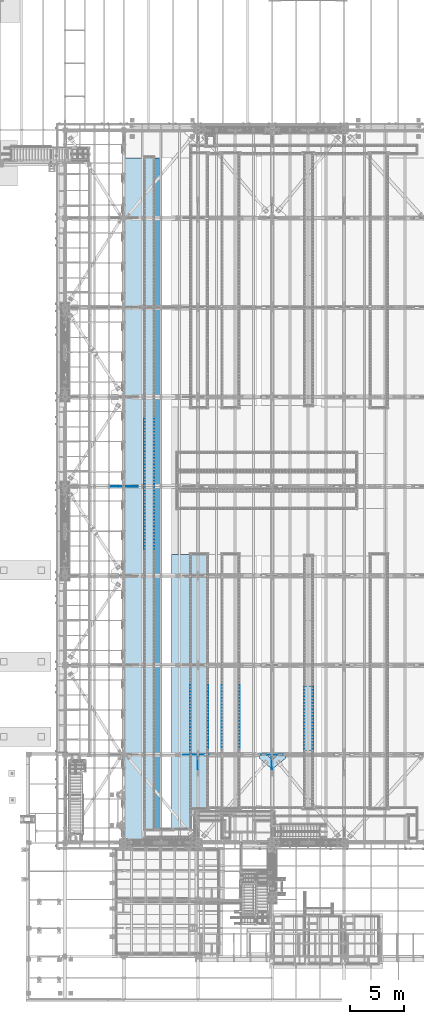
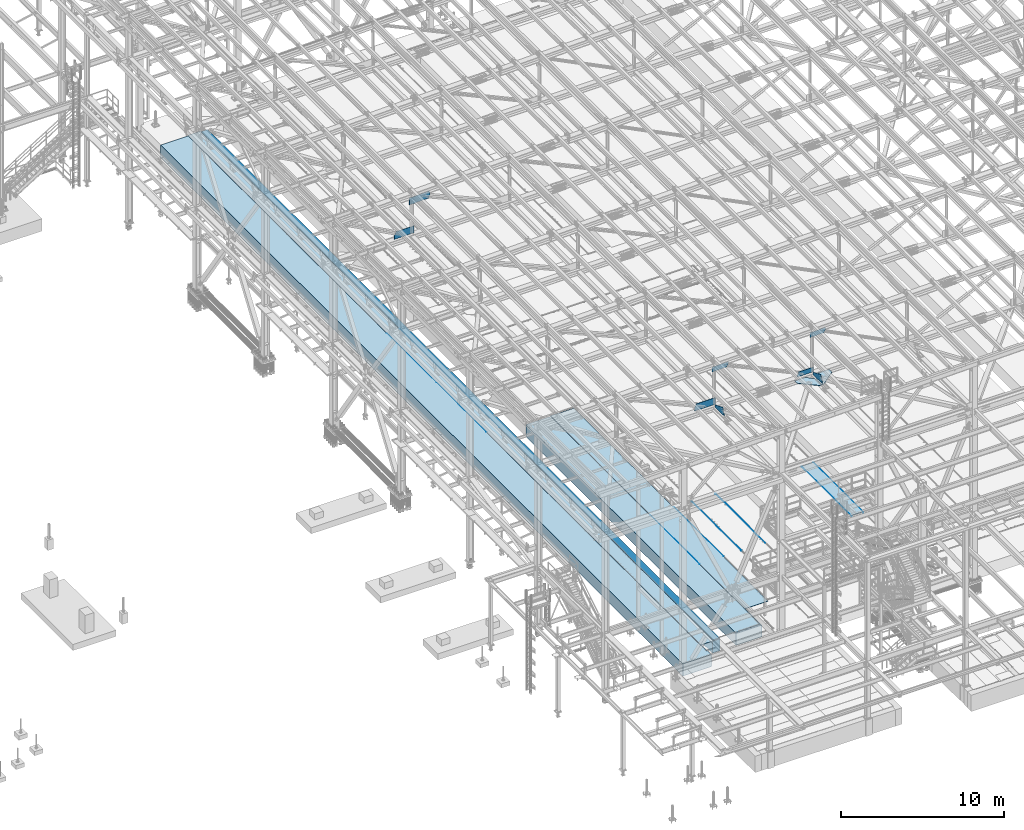
# One storey, part 2979 of 3843: 23 plates, 3 slabs, 24 elements without a shape of their own.
"""IFC2X3 building model written with IfcOpenShell, lengths in millimetres."""

from ifc_helpers import new_model, si_unit, frame, origin_with_axes, place, context, subcontext, project, spatial, faceted_brep, material, type_object, element, aggregate, save


model = new_model("IFC2X3")

# Units and contexts
model_context = context("Model", 3, precision=1e-05, world=origin_with_axes())
body_context = subcontext(model_context, "Body", "Model", "MODEL_VIEW")
ifc_project = project(units=[si_unit("LENGTHUNIT", "METRE", prefix="MILLI"), si_unit("AREAUNIT", "SQUARE_METRE"), si_unit("VOLUMEUNIT", "CUBIC_METRE"), si_unit("MASSUNIT", "GRAM", prefix="KILO"), si_unit("TIMEUNIT", "SECOND"), si_unit("PLANEANGLEUNIT", "RADIAN"), si_unit("SOLIDANGLEUNIT", "STERADIAN"), si_unit("THERMODYNAMICTEMPERATUREUNIT", "DEGREE_CELSIUS"), si_unit("LUMINOUSINTENSITYUNIT", "LUMEN")], contexts=[model_context])

# Site, building, storey
site_placement = place(None, origin_with_axes())
site = spatial("IfcSite", under=ifc_project, at=site_placement, CompositionType="ELEMENT")
building_placement = place(site_placement, origin_with_axes())
building = spatial("IfcBuilding", under=site, at=building_placement, Name="Undefined", CompositionType="ELEMENT")
storey_placement = place(building_placement, origin_with_axes())
storey = spatial("IfcBuildingStorey", under=building, at=storey_placement, Name="Undefined", CompositionType="ELEMENT", Elevation=0.0)

# Assembly, plate
assembly_1_placement = place(storey_placement, origin_with_axes())
assembly_1 = element("IfcElementAssembly", 1, at=assembly_1_placement, inside=storey, Name="EMBED_ANGLE", AssemblyPlace="NOTDEFINED", PredefinedType="RIGID_FRAME")
ifc_material_1 = material(Name="STEEL/A36")
plate_type_1 = type_object("IfcPlateType", PredefinedType="NOTDEFINED")
plate_1_placement = place(assembly_1_placement, frame((59735.2121396484, 40208.072265625, 30479.9999996185), z_axis=(0.0, -1.0, 0.0), x_axis=(0.0, 0.0, -1.0)))
plate_1 = element("IfcPlate", 2, at=plate_1_placement, type_object=plate_type_1, material=ifc_material_1, Name="PLATE", context=body_context, shape_type="Brep", body=[
    faceted_brep([(25.4000008230432, 1.58705903157534, 6096.0), (25.3999996185303, 1.58706242449261, 0.0), (20.6374996185295, 6.35000000000218, -7.27595761418343e-12), (20.6374984696922, 6.35000000000582, 6096.0), (0.0, -6.3499999046162, 0.0), (3.81471181754023e-07, -6.34999999999854, 6096.0), (3.81471181754023e-07, 6.34999999999854, 6096.0), (7.27595761418343e-12, 6.3499999046162, 0.0), (25.3999996185303, -6.34999999999491, 2.91038304567337e-11), (25.3999996185303, -6.35000000000582, 6096.0)], [[[0, 1, 2, 3]], [[4, 5, 6, 7]], [[8, 9, 5, 4]], [[6, 5, 9, 0, 3]], [[7, 6, 3, 2]], [[8, 4, 7, 2, 1]], [[9, 8, 1, 0]]]),
])
aggregate(assembly_1, [plate_1])

assembly_2_placement = place(storey_placement, origin_with_axes())
assembly_2 = element("IfcElementAssembly", 3, at=assembly_2_placement, inside=storey, Name="EMBED_ANGLE", AssemblyPlace="NOTDEFINED", PredefinedType="RIGID_FRAME")
plate_2_placement = place(assembly_2_placement, frame((58909.7753603516, 40208.072265625, 30479.9999996185), z_axis=(0.0, -1.0, 0.0), x_axis=(0.0, 0.0, -1.0)))
plate_2 = element("IfcPlate", 4, at=plate_2_placement, type_object=plate_type_1, material=ifc_material_1, Name="PLATE", context=body_context, shape_type="Brep", body=[
    faceted_brep([(25.3999996185521, -1.58750000003783, 6096.0), (20.6375003814719, -6.34999999999854, 6096.00000000139), (20.6375000381231, -6.35000000004948, 2.5465851649642e-11), (25.3999996185921, -1.5874999999869, 7.27595761418343e-11), (0.0, -6.3499999046162, 0.0), (3.81471181754023e-07, -6.34999999999854, 6096.0), (3.81471181754023e-07, 6.34999999999854, 6096.0), (7.27595761418343e-12, 6.3499999046162, 0.0), (25.3999996185303, 6.34999999999854, 6096.00000000171), (25.3999999999942, 6.34999999994034, 2.91038304567337e-11)], [[[0, 1, 2, 3]], [[4, 5, 6, 7]], [[8, 9, 7, 6]], [[9, 8, 0, 3]], [[4, 7, 9, 3, 2]], [[5, 4, 2, 1]], [[8, 6, 5, 1, 0]]]),
])
aggregate(assembly_2, [plate_2])

assembly_3_placement = place(storey_placement, origin_with_axes())
assembly_3 = element("IfcElementAssembly", 5, at=assembly_3_placement, inside=storey, Name="EMBED_ANGLE", AssemblyPlace="NOTDEFINED", PredefinedType="RIGID_FRAME")
plate_3_placement = place(assembly_3_placement, frame((52889.8485419922, 40360.599609375, 30479.9999996185), z_axis=(0.0, -1.0, 0.0), x_axis=(0.0, 0.0, -1.0)))
plate_3 = element("IfcPlate", 6, at=plate_3_placement, type_object=plate_type_1, material=ifc_material_1, Name="PLATE", context=body_context, shape_type="Brep", body=[
    faceted_brep([(25.4000008230432, 1.58705903157534, 6096.0), (25.3999996185303, 1.58706242449261, 0.0), (20.6374996185295, 6.35000000000218, -7.27595761418343e-12), (20.6374984696922, 6.35000000000582, 6096.0), (0.0, -6.3499999046162, 0.0), (3.81471181754023e-07, -6.34999999999854, 6096.0), (3.81471181754023e-07, 6.34999999999854, 6096.0), (7.27595761418343e-12, 6.3499999046162, 0.0), (25.3999996185303, -6.34999999999491, 2.91038304567337e-11), (25.3999996185303, -6.35000000000582, 6096.0)], [[[0, 1, 2, 3]], [[4, 5, 6, 7]], [[8, 9, 5, 4]], [[6, 5, 9, 0, 3]], [[7, 6, 3, 2]], [[8, 4, 7, 2, 1]], [[9, 8, 1, 0]]]),
])
aggregate(assembly_3, [plate_3])

assembly_4_placement = place(storey_placement, origin_with_axes())
assembly_4 = element("IfcElementAssembly", 7, at=assembly_4_placement, inside=storey, Name="EMBED_ANGLE", AssemblyPlace="NOTDEFINED", PredefinedType="RIGID_FRAME")
plate_4_placement = place(assembly_4_placement, frame((51200.811984375, 40360.599609375, 30479.9999996185), z_axis=(0.0, -1.0, 0.0), x_axis=(0.0, 0.0, -1.0)))
plate_4 = element("IfcPlate", 8, at=plate_4_placement, type_object=plate_type_1, material=ifc_material_1, Name="PLATE", context=body_context, shape_type="Brep", body=[
    faceted_brep([(25.3999996185521, -1.58750000003783, 6096.0), (20.6375003814719, -6.34999999999854, 6096.00000000139), (20.6375000381231, -6.35000000004948, 2.5465851649642e-11), (25.3999996185921, -1.5874999999869, 7.27595761418343e-11), (0.0, -6.3499999046162, 0.0), (3.81471181754023e-07, -6.34999999999854, 6096.0), (3.81471181754023e-07, 6.34999999999854, 6096.0), (7.27595761418343e-12, 6.3499999046162, 0.0), (25.3999996185303, 6.34999999999854, 6096.00000000171), (25.3999999999942, 6.34999999994034, 2.91038304567337e-11)], [[[0, 1, 2, 3]], [[4, 5, 6, 7]], [[8, 9, 7, 6]], [[9, 8, 0, 3]], [[4, 7, 9, 3, 2]], [[5, 4, 2, 1]], [[8, 6, 5, 1, 0]]]),
])
aggregate(assembly_4, [plate_4])

assembly_5_placement = place(storey_placement, origin_with_axes())
assembly_5 = element("IfcElementAssembly", 9, at=assembly_5_placement, inside=storey, Name="EMBED_ANGLE", AssemblyPlace="NOTDEFINED", PredefinedType="RIGID_FRAME")
plate_5_placement = place(assembly_5_placement, frame((49949.8620576172, 40360.599609375, 30479.9999996185), z_axis=(0.0, -1.0, 0.0), x_axis=(0.0, 0.0, -1.0)))
plate_5 = element("IfcPlate", 10, at=plate_5_placement, type_object=plate_type_1, material=ifc_material_1, Name="PLATE", context=body_context, shape_type="Brep", body=[
    faceted_brep([(25.4000008230432, 1.58705903157534, 6096.0), (25.3999996185303, 1.58706242449261, 0.0), (20.6374996185295, 6.35000000000218, -7.27595761418343e-12), (20.6374984696922, 6.35000000000582, 6096.0), (0.0, -6.3499999046162, 0.0), (3.81471181754023e-07, -6.34999999999854, 6096.0), (3.81471181754023e-07, 6.34999999999854, 6096.0), (7.27595761418343e-12, 6.3499999046162, 0.0), (25.3999996185303, -6.34999999999491, 2.91038304567337e-11), (25.3999996185303, -6.35000000000582, 6096.0)], [[[0, 1, 2, 3]], [[4, 5, 6, 7]], [[8, 9, 5, 4]], [[6, 5, 9, 0, 3]], [[7, 6, 3, 2]], [[8, 4, 7, 2, 1]], [[9, 8, 1, 0]]]),
])
aggregate(assembly_5, [plate_5])

assembly_6_placement = place(storey_placement, origin_with_axes())
assembly_6 = element("IfcElementAssembly", 11, at=assembly_6_placement, inside=storey, Name="EMBED_ANGLE", AssemblyPlace="NOTDEFINED", PredefinedType="RIGID_FRAME")
plate_6_placement = place(assembly_6_placement, frame((48260.7616210937, 40360.6001953125, 30479.9999996185), z_axis=(0.0, -1.0, 0.0), x_axis=(0.0, 0.0, -1.0)))
plate_6 = element("IfcPlate", 12, at=plate_6_placement, type_object=plate_type_1, material=ifc_material_1, Name="PLATE", context=body_context, shape_type="Brep", body=[
    faceted_brep([(25.3999996185521, -1.58750000003783, 6096.0), (20.6375003814719, -6.34999999999854, 6096.00000000139), (20.6375000381231, -6.35000000004948, 2.5465851649642e-11), (25.3999996185921, -1.5874999999869, 7.27595761418343e-11), (0.0, -6.3499999046162, 0.0), (3.81471181754023e-07, -6.34999999999854, 6096.0), (3.81471181754023e-07, 6.34999999999854, 6096.0), (7.27595761418343e-12, 6.3499999046162, 0.0), (25.3999996185303, 6.34999999999854, 6096.00000000171), (25.3999999999942, 6.34999999994034, 2.91038304567337e-11)], [[[0, 1, 2, 3]], [[4, 5, 6, 7]], [[8, 9, 7, 6]], [[9, 8, 0, 3]], [[4, 7, 9, 3, 2]], [[5, 4, 2, 1]], [[8, 6, 5, 1, 0]]]),
])
aggregate(assembly_6, [plate_6])

assembly_7_placement = place(storey_placement, origin_with_axes())
assembly_7 = element("IfcElementAssembly", 13, at=assembly_7_placement, inside=storey, Name="PLATE", AssemblyPlace="NOTDEFINED", PredefinedType="RIGID_FRAME")
ifc_material_2 = material(Name="STEEL/A572-50")
plate_type_2 = type_object("IfcPlateType", PredefinedType="NOTDEFINED")
plate_7_placement = place(assembly_7_placement, frame((58922.4753962742, 34175.5721406259, 30467.3), z_axis=(0.0, 1.0, 0.0), x_axis=(1.0, 0.0, 0.0)))
plate_7 = element("IfcPlate", 14, at=plate_7_placement, type_object=plate_type_2, material=ifc_material_2, Name="PLATE", context=body_context, shape_type="Brep", body=[
    faceted_brep([(0.0, -12.6999999999971, 0.0), (-0.00374851834203582, -12.7000000000007, 6095.99999999916), (-0.00374851834203582, 12.7000000000007, 6095.99999999916), (0.0, 12.6999999999971, 0.0), (800.03667504531, -12.7000000000007, 6096.00000000056), (800.03667504531, 12.7000000000007, 6096.00000000056), (800.036639650629, -12.7000000000007, 5.49334799870849e-10), (800.036639650629, 12.7000000000007, 5.49334799870849e-10)], [[[0, 1, 2, 3]], [[1, 4, 5, 2]], [[4, 6, 7, 5]], [[6, 0, 3, 7]], [[5, 7, 3, 2]], [[6, 4, 1, 0]]]),
])
aggregate(assembly_7, [plate_7])

assembly_8_placement = place(storey_placement, origin_with_axes())
assembly_8 = element("IfcElementAssembly", 15, at=assembly_8_placement, inside=storey, Name="BEAM", AssemblyPlace="NOTDEFINED", PredefinedType="RIGID_FRAME")
plate_type_3 = type_object("IfcPlateType", PredefinedType="NOTDEFINED")
plate_8_placement = place(assembly_8_placement, frame((42268.3401981071, 58915.2999999999, 42463.0727281937), z_axis=(-0.00524699200232136, 0.0, 0.999986234442719), x_axis=(-0.999986234442719, 0.0, -0.00524699200232052)))
plate_8 = element("IfcPlate", 16, at=plate_8_placement, type_object=plate_type_3, material=ifc_material_2, Name="PLATE", context=body_context, shape_type="Brep", body=[
    faceted_brep([(0.0, -9.52500000000146, 0.0), (1.229636836797e-09, -9.52500000000146, 522.241740626429), (1.229636836797e-09, 9.52500000000146, 522.241740626429), (0.0, 9.52500000000146, 0.0), (1253.2324914307, -9.52500000000146, 528.817531697183), (1253.2324914307, 9.52500000000146, 528.817531697183), (1398.7446886287, -9.52500000000146, 260.994378102703), (1398.7446886287, 9.52500000000146, 260.994378102703), (1398.74468862808, -9.52500000000146, -3.32511262968183e-09), (1398.74468862808, 9.52500000000146, -3.32511262968183e-09)], [[[0, 1, 2, 3]], [[1, 4, 5, 2]], [[4, 6, 7, 5]], [[6, 8, 9, 7]], [[8, 0, 3, 9]], [[5, 7, 9, 3, 2]], [[8, 6, 4, 1, 0]]]),
])
aggregate(assembly_8, [plate_8])

assembly_9_placement = place(storey_placement, origin_with_axes())
assembly_9 = element("IfcElementAssembly", 17, at=assembly_9_placement, inside=storey, Name="TRENCH COVER", AssemblyPlace="NOTDEFINED", PredefinedType="RIGID_FRAME")
ifc_material_3 = material(Name="STEEL/Steel_Undefined")
plate_type_4 = type_object("IfcPlateType", PredefinedType="NOTDEFINED")
plate_9_placement = place(assembly_9_placement, frame((48279.8099164624, 28809.9499739415, 30467.3), z_axis=(0.0, 1.0, 0.0), x_axis=(1.0, 0.0, 0.0)))
plate_9 = element("IfcPlate", 18, at=plate_9_placement, type_object=plate_type_4, material=ifc_material_3, Name="TRENCH COVER", context=body_context, shape_type="Brep", body=[
    faceted_brep([(0.0, -12.6999999999971, 0.0), (0.00638351428642636, -12.7000000000007, 23806.1500596228), (0.00638351428642636, 12.7000000000007, 23806.1500596228), (0.0, 12.6999999999971, 0.0), (1651.00000084208, -12.7000000000007, 23806.1500595694), (1651.00000084208, 12.7000000000007, 23806.1500595694), (1651.0, -12.7000000000007, 0.0), (1651.0, 12.7000000000007, 0.0)], [[[0, 1, 2, 3]], [[1, 4, 5, 2]], [[4, 6, 7, 5]], [[6, 0, 3, 7]], [[5, 7, 3, 2]], [[6, 4, 1, 0]]]),
])
aggregate(assembly_9, [plate_9])

assembly_10_placement = place(storey_placement, origin_with_axes())
assembly_10 = element("IfcElementAssembly", 19, at=assembly_10_placement, inside=storey, Name="TRENCH COVER", AssemblyPlace="NOTDEFINED", PredefinedType="RIGID_FRAME")
plate_type_5 = type_object("IfcPlateType", PredefinedType="NOTDEFINED")
plate_10_placement = place(assembly_10_placement, frame((44017.9460147894, 26806.5255152289, 30472.0625), z_axis=(0.0, 1.0, 0.0), x_axis=(1.0, 0.0, 0.0)))
plate_10 = element("IfcPlate", 20, at=plate_10_placement, type_object=plate_type_5, material=ifc_material_3, Name="TRENCH COVER", context=body_context, shape_type="Brep", body=[
    faceted_brep([(0.0, -7.9375, 0.0), (0.000500683752761688, -7.9375, 62871.3494847712), (0.000500683752761688, 7.9375, 62871.3494847712), (0.0, 7.9375, 0.0), (889.000485894358, -7.9375, 62871.3494776559), (889.000485894358, 7.9375, 62871.3494776559), (888.99997705764, -7.9375, 4.51109372079372e-10), (888.99997705764, 7.9375, 4.51109372079372e-10)], [[[0, 1, 2, 3]], [[1, 4, 5, 2]], [[4, 6, 7, 5]], [[6, 0, 3, 7]], [[5, 7, 3, 2]], [[6, 4, 1, 0]]]),
])
aggregate(assembly_10, [plate_10])

assembly_11_placement = place(storey_placement, origin_with_axes())
assembly_11 = element("IfcElementAssembly", 21, at=assembly_11_placement, inside=storey, Name="EMBED_ANGLE", AssemblyPlace="NOTDEFINED", PredefinedType="RIGID_FRAME")
plate_type_6 = type_object("IfcPlateType", PredefinedType="NOTDEFINED")
plate_11_placement = place(assembly_11_placement, frame((44925.9959999999, 59134.3749999999, 30479.9999984742), z_axis=(0.0, -1.0, 0.0), x_axis=(0.0, 0.0, -1.0)))
plate_11 = element("IfcPlate", 22, at=plate_11_placement, type_object=plate_type_6, material=ifc_material_1, Name="PLATE", context=body_context, shape_type="Brep", body=[
    faceted_brep([(15.875, 1.58750000000146, 6096.0), (15.875, 1.58749999204883, -3.63797880709171e-12), (11.1125018504281, 6.35000000000582, -7.27595761418343e-12), (11.1124996186481, 6.34999999999854, 6096.0), (0.0, -6.3499999046162, 0.0), (3.81471181754023e-07, -6.34999999999854, 6096.0), (3.81471181754023e-07, 6.34999999999854, 6096.0), (7.27595761418343e-12, 6.3499999046162, 0.0), (15.875, -6.35000000000582, 3.63797880709171e-12), (15.875, -6.34999999999854, 6096.0)], [[[0, 1, 2, 3]], [[4, 5, 6, 7]], [[8, 9, 5, 4]], [[6, 5, 9, 0, 3]], [[7, 6, 3, 2]], [[8, 4, 7, 2, 1]], [[9, 8, 1, 0]]]),
])
aggregate(assembly_11, [plate_11])

assembly_12_placement = place(storey_placement, origin_with_axes())
assembly_12 = element("IfcElementAssembly", 23, at=assembly_12_placement, inside=storey, Name="EMBED_ANGLE", AssemblyPlace="NOTDEFINED", PredefinedType="RIGID_FRAME")
plate_12_placement = place(assembly_12_placement, frame((44925.996, 65230.375, 30479.9999988556), z_axis=(0.0, -1.0, 0.0), x_axis=(0.0, 0.0, -1.0)))
plate_12 = element("IfcPlate", 24, at=plate_12_placement, type_object=plate_type_6, material=ifc_material_1, Name="PLATE", context=body_context, shape_type="Brep", body=[
    faceted_brep([(15.875, 1.58750000000146, 6096.0), (15.875, 1.58749999204883, -3.63797880709171e-12), (11.1125018504281, 6.35000000000582, -7.27595761418343e-12), (11.1124996186481, 6.34999999999854, 6096.0), (0.0, -6.3499999046162, 0.0), (3.81471181754023e-07, -6.34999999999854, 6096.0), (3.81471181754023e-07, 6.34999999999854, 6096.0), (7.27595761418343e-12, 6.3499999046162, 0.0), (15.875, -6.35000000000582, 3.63797880709171e-12), (15.875, -6.34999999999854, 6096.0)], [[[0, 1, 2, 3]], [[4, 5, 6, 7]], [[8, 9, 5, 4]], [[6, 5, 9, 0, 3]], [[7, 6, 3, 2]], [[8, 4, 7, 2, 1]], [[9, 8, 1, 0]]]),
])
aggregate(assembly_12, [plate_12])

assembly_13_placement = place(storey_placement, origin_with_axes())
assembly_13 = element("IfcElementAssembly", 25, at=assembly_13_placement, inside=storey, Name="EMBED_ANGLE", AssemblyPlace="NOTDEFINED", PredefinedType="RIGID_FRAME")
plate_13_placement = place(assembly_13_placement, frame((43998.896, 59134.375, 30479.9999988556), z_axis=(0.0, -1.0, 0.0), x_axis=(0.0, 0.0, -1.0)))
plate_13 = element("IfcPlate", 26, at=plate_13_placement, type_object=plate_type_6, material=ifc_material_1, Name="PLATE", context=body_context, shape_type="Brep", body=[
    faceted_brep([(15.8749946755343, -1.58750000000146, 6096.0), (11.1124999999702, -6.34999999999854, 6096.0), (11.1125001907349, -6.35000000006371, 0.0), (15.875, -1.58750000024156, -3.63797880709171e-12), (0.0, -6.3499999046162, 0.0), (3.81471181754023e-07, -6.34999999999854, 6096.0), (3.81471181754023e-07, 6.34999999999854, 6096.0), (7.27595761418343e-12, 6.3499999046162, 0.0), (15.875, 6.34999999999854, 6096.0), (15.875, 6.34999999999854, -3.63797880709171e-12)], [[[0, 1, 2, 3]], [[4, 5, 6, 7]], [[8, 9, 7, 6]], [[9, 8, 0, 3]], [[4, 7, 9, 3, 2]], [[5, 4, 2, 1]], [[8, 6, 5, 1, 0]]]),
])
aggregate(assembly_13, [plate_13])

assembly_14_placement = place(storey_placement, origin_with_axes())
assembly_14 = element("IfcElementAssembly", 27, at=assembly_14_placement, inside=storey, Name="EMBED_ANGLE", AssemblyPlace="NOTDEFINED", PredefinedType="RIGID_FRAME")
plate_14_placement = place(assembly_14_placement, frame((43998.896, 65230.375, 30479.9999992371), z_axis=(0.0, -1.0, 0.0), x_axis=(0.0, 0.0, -1.0)))
plate_14 = element("IfcPlate", 28, at=plate_14_placement, type_object=plate_type_6, material=ifc_material_1, Name="PLATE", context=body_context, shape_type="Brep", body=[
    faceted_brep([(15.8749946755343, -1.58750000000146, 6096.0), (11.1124999999702, -6.34999999999854, 6096.0), (11.1125001907349, -6.35000000006371, 0.0), (15.875, -1.58750000024156, -3.63797880709171e-12), (0.0, -6.3499999046162, 0.0), (3.81471181754023e-07, -6.34999999999854, 6096.0), (3.81471181754023e-07, 6.34999999999854, 6096.0), (7.27595761418343e-12, 6.3499999046162, 0.0), (15.875, 6.34999999999854, 6096.0), (15.875, 6.34999999999854, -3.63797880709171e-12)], [[[0, 1, 2, 3]], [[4, 5, 6, 7]], [[8, 9, 7, 6]], [[9, 8, 0, 3]], [[4, 7, 9, 3, 2]], [[5, 4, 2, 1]], [[8, 6, 5, 1, 0]]]),
])
aggregate(assembly_14, [plate_14])

assembly_15_placement = place(storey_placement, origin_with_axes())
assembly_15 = element("IfcElementAssembly", 29, at=assembly_15_placement, inside=storey, Name="PLATE", AssemblyPlace="NOTDEFINED", PredefinedType="RIGID_FRAME")
plate_type_7 = type_object("IfcPlateType", PredefinedType="NOTDEFINED")
plate_15_placement = place(assembly_15_placement, frame((55937.1500000002, 33362.9, 42232.2630004883), z_axis=(1.0, 0.0, 0.0), x_axis=(0.0, -1.0, 0.0)))
plate_15 = element("IfcPlate", 30, at=plate_15_placement, type_object=plate_type_7, material=ifc_material_2, Name="PLATE", context=body_context, shape_type="Brep", body=[
    faceted_brep([(0.0, -14.2874999999985, 0.0), (-475.45624995463, -14.2874999999985, 476.25000003165), (-475.45624995463, 14.2874999999985, 476.25000003165), (0.0, 14.2874999999985, 0.0), (-475.45624994392, -14.2874999999985, 1212.85000003893), (-475.45624994392, 14.2874999999985, 1212.85000003893), (-131.350926281884, -14.2874999999985, 1212.8499999995), (-131.350926281884, 14.2874999999985, 1212.8499999995), (736.600000090519, -14.2874999999985, 147.637499993114), (736.600000090519, 14.2874999999985, 147.637499993114), (736.599999940488, -14.2874999999985, 0.0), (736.599999940488, 14.2874999999985, 0.0)], [[[0, 1, 2, 3]], [[1, 4, 5, 2]], [[4, 6, 7, 5]], [[6, 8, 9, 7]], [[8, 10, 11, 9]], [[10, 0, 3, 11]], [[5, 7, 9, 11, 3, 2]], [[10, 8, 6, 4, 1, 0]]]),
])
aggregate(assembly_15, [plate_15])

assembly_16_placement = place(storey_placement, origin_with_axes())
assembly_16 = element("IfcElementAssembly", 31, at=assembly_16_placement, inside=storey, Name="PLATE", AssemblyPlace="NOTDEFINED", PredefinedType="RIGID_FRAME")
plate_16_placement = place(assembly_16_placement, frame((55448.2, 33838.3562499839, 42232.2630004883), z_axis=(0.0, -1.0, 0.0), x_axis=(-1.0, 0.0, 0.0)))
plate_16 = element("IfcPlate", 32, at=plate_16_placement, type_object=plate_type_7, material=ifc_material_2, Name="PLATE", context=body_context, shape_type="Brep", body=[
    faceted_brep([(0.0, -14.2874999999985, 0.0), (-476.249999993554, -14.2874999999985, 475.456250073548), (-476.249999993554, 14.2874999999985, 475.456250073548), (0.0, 14.2874999999985, 0.0), (-476.249999993568, -14.2874999999985, 1212.05625003844), (-476.249999993568, 14.2874999999985, 1212.05625003844), (-328.612500000025, -14.2874999999985, 1212.05625001177), (-328.612500000025, 14.2874999999985, 1212.05625001177), (736.599999999977, -14.2874999999985, 314.516088359618), (736.599999999977, 14.2874999999985, 314.516088359618), (736.599999940488, -14.2874999999985, 0.0), (736.599999940488, 14.2874999999985, 0.0)], [[[0, 1, 2, 3]], [[1, 4, 5, 2]], [[4, 6, 7, 5]], [[6, 8, 9, 7]], [[8, 10, 11, 9]], [[10, 0, 3, 11]], [[5, 7, 9, 11, 3, 2]], [[10, 8, 6, 4, 1, 0]]]),
])
aggregate(assembly_16, [plate_16])

assembly_17_placement = place(storey_placement, origin_with_axes())
assembly_17 = element("IfcElementAssembly", 33, at=assembly_17_placement, inside=storey, Name="BEAM", AssemblyPlace="NOTDEFINED", PredefinedType="RIGID_FRAME")
plate_type_8 = type_object("IfcPlateType", PredefinedType="NOTDEFINED")
plate_17_placement = place(assembly_17_placement, frame((48972.7875, 32494.8673194311, 42408.7251975744), z_axis=(0.0, -0.000728692999644406, 0.999999734503221), x_axis=(0.0, 0.999999734503221, 0.000728692999635592)))
plate_17 = element("IfcPlate", 34, at=plate_17_placement, type_object=plate_type_8, material=ifc_material_2, context=body_context, shape_type="Brep", body=[
    faceted_brep([(0.0, -7.9375, 0.0), (-1.45519152283669e-10, -7.9375, 89.4662383458563), (-1.45519152283669e-10, 7.9375, 89.4662383458563), (0.0, 7.9375, 0.0), (186.327115425451, -7.9375, 562.061420348924), (186.327115425451, 7.9375, 562.061420348924), (1137.11428243793, -7.9375, 177.79999999619), (1137.11428243793, 7.9375, 177.79999999619), (1137.11428243822, -7.9375, -2.2409949451685e-09), (1137.11428243822, 7.9375, -2.2409949451685e-09)], [[[0, 1, 2, 3]], [[1, 4, 5, 2]], [[4, 6, 7, 5]], [[6, 8, 9, 7]], [[8, 0, 3, 9]], [[5, 7, 9, 3, 2]], [[8, 6, 4, 1, 0]]]),
])

assembly_18_placement = place(storey_placement, origin_with_axes())
assembly_18 = element("IfcElementAssembly", 35, at=assembly_18_placement, inside=storey, Name="BEAM", AssemblyPlace="NOTDEFINED", PredefinedType="RIGID_FRAME")
plate_type_9 = type_object("IfcPlateType", PredefinedType="NOTDEFINED")
plate_18_placement = place(assembly_18_placement, frame((55906.9875, 32494.427436544, 42411.5232346845), z_axis=(0.0, -0.00113550900035625, 0.999999355309447), x_axis=(0.0, 0.999999355309447, 0.00113550900035246)))
plate_18 = element("IfcPlate", 36, at=plate_18_placement, type_object=plate_type_9, material=ifc_material_2, context=body_context, shape_type="Brep", body=[
    faceted_brep([(0.0, -7.9375, 0.0), (1.20053300634027e-10, -7.9375, 104.906484073603), (1.20053300634027e-10, 7.9375, 104.906484073603), (0.0, 7.9375, 0.0), (193.746784921019, -7.9375, 574.50863838027), (193.746784921019, 7.9375, 574.50863838027), (1137.55468434726, -7.9375, 177.800000001196), (1137.55468434726, 7.9375, 177.800000001196), (1137.55468434704, -7.9375, 2.77213985100389e-09), (1137.55468434704, 7.9375, 2.77213985100389e-09)], [[[0, 1, 2, 3]], [[1, 4, 5, 2]], [[4, 6, 7, 5]], [[6, 8, 9, 7]], [[8, 0, 3, 9]], [[5, 7, 9, 3, 2]], [[8, 6, 4, 1, 0]]]),
])

assembly_19_placement = place(storey_placement, origin_with_axes())
assembly_19 = element("IfcElementAssembly", 37, at=assembly_19_placement, inside=storey, Name="BEAM", AssemblyPlace="NOTDEFINED", PredefinedType="RIGID_FRAME")
plate_type_10 = type_object("IfcPlateType", PredefinedType="NOTDEFINED")
plate_19_placement = place(assembly_19_placement, frame((50020.8963118979, 33845.5, 45315.5211754243), z_axis=(0.0216342480057937, 0.0, -0.999765952267441), x_axis=(-0.999765952267441, 0.0, -0.0216342480057875)))
plate_19 = element("IfcPlate", 38, at=plate_19_placement, type_object=plate_type_10, material=ifc_material_2, Name="PLATE", context=body_context, shape_type="Brep", body=[
    faceted_brep([(0.0, -9.52500000000146, 0.0), (-1.81898940354586e-10, -9.52500000000146, 136.28127721449), (-1.81898940354586e-10, 9.52500000000146, 136.28127721449), (0.0, 9.52500000000146, 0.0), (112.32409765022, -9.52500000000146, 364.095449729706), (112.32409765022, 9.52500000000146, 364.095449729706), (1146.7416375599, -9.52500000000146, 364.095449731023), (1146.7416375599, 9.52500000000146, 364.095449731023), (1138.86286156529, -9.52500000000146, 1.43336364999413e-09), (1138.86286156529, 9.52500000000146, 1.43336364999413e-09)], [[[0, 1, 2, 3]], [[1, 4, 5, 2]], [[4, 6, 7, 5]], [[6, 8, 9, 7]], [[8, 0, 3, 9]], [[5, 7, 9, 3, 2]], [[8, 6, 4, 1, 0]]]),
])
aggregate(assembly_19, [plate_19])

assembly_20_placement = place(storey_placement, origin_with_axes())
assembly_20 = element("IfcElementAssembly", 39, at=assembly_20_placement, inside=storey, Name="BEAM", AssemblyPlace="NOTDEFINED", PredefinedType="RIGID_FRAME")
plate_type_11 = type_object("IfcPlateType", PredefinedType="NOTDEFINED")
plate_20_placement = place(assembly_20_placement, frame((43374.0278140846, 58915.3, 45206.0382975926), z_axis=(0.0263345930122524, 0.0, -0.999653184464932), x_axis=(-0.999653184464932, 0.0, -0.0263345930122488)))
plate_20 = element("IfcPlate", 40, at=plate_20_placement, type_object=plate_type_11, material=ifc_material_2, Name="PLATE", context=body_context, shape_type="Brep", body=[
    faceted_brep([(0.0, -9.52500000000146, 0.0), (-5.74800651520491e-10, -9.52499999999418, 280.521759244722), (-5.74800651520491e-10, 9.52500000000873, 280.521759244722), (0.0, 9.52500000000146, 0.0), (108.620659158485, -9.52499999999418, 510.12479612077), (108.620659158485, 9.52500000000873, 510.12479612077), (1452.56551634456, -9.52499999999418, 510.124796123513), (1452.56551634456, 9.52500000000873, 510.124796123513), (1439.12692660526, -9.52499999999418, 2.93221091851592e-09), (1439.12692660526, 9.52500000000873, 2.93221091851592e-09)], [[[0, 1, 2, 3]], [[1, 4, 5, 2]], [[4, 6, 7, 5]], [[6, 8, 9, 7]], [[8, 0, 3, 9]], [[5, 7, 9, 3, 2]], [[8, 6, 4, 1, 0]]]),
])
aggregate(assembly_20, [plate_20])

assembly_21_placement = place(storey_placement, origin_with_axes())
assembly_21 = element("IfcElementAssembly", 41, at=assembly_21_placement, inside=storey, Name="BEAM", AssemblyPlace="NOTDEFINED", PredefinedType="RIGID_FRAME")
plate_type_12 = type_object("IfcPlateType", PredefinedType="NOTDEFINED")
plate_21_placement = place(assembly_21_placement, frame((56893.5918887739, 33845.5, 45464.2415974404), z_axis=(0.0216342480057937, 0.0, -0.999765952267441), x_axis=(-0.999765952267441, 0.0, -0.0216342480057875)))
plate_21 = element("IfcPlate", 42, at=plate_21_placement, type_object=plate_type_12, material=ifc_material_2, Name="PLATE", context=body_context, shape_type="Brep", body=[
    faceted_brep([(0.0, -9.52500000000146, 0.0), (-1.89174897968769e-10, -9.52500000000146, 154.676499150606), (-1.89174897968769e-10, 9.52500000000146, 154.676499150606), (0.0, 9.52500000000146, 0.0), (107.315225856008, -9.52500000000146, 356.521498296774), (107.315225856008, 9.52500000000146, 356.521498296774), (1085.05891984225, -9.52500000000146, 356.521498298011), (1085.05891984225, 9.52500000000146, 356.521498298011), (1077.34403896574, -9.52500000000146, 1.35332811623812e-09), (1077.34403896574, 9.52500000000146, 1.35332811623812e-09)], [[[0, 1, 2, 3]], [[1, 4, 5, 2]], [[4, 6, 7, 5]], [[6, 8, 9, 7]], [[8, 0, 3, 9]], [[5, 7, 9, 3, 2]], [[8, 6, 4, 1, 0]]]),
])
aggregate(assembly_21, [plate_21])

# Plate
plate_type_13 = type_object("IfcPlateType", PredefinedType="NOTDEFINED")
plate_22_placement = place(assembly_18_placement, frame((56045.2725856442, 33845.5, 42440.1000793865), z_axis=(-0.00048281500021403, 0.0, 0.999999883444831), x_axis=(-0.999999883445314, 0.0, -0.000482814000210543)))
plate_22 = element("IfcPlate", 43, at=plate_22_placement, type_object=plate_type_13, material=ifc_material_2, Name="PLATE", context=body_context, shape_type="Brep", body=[
    faceted_brep([(0.0, -9.52500000000146, 0.0), (-9.09494701772928e-10, -9.52500000000146, 357.965528898043), (-9.09494701772928e-10, 9.52500000000146, 357.965528898043), (0.0, 9.52500000000146, 0.0), (1036.31812602505, -9.52500000000146, 358.465878891038), (1036.31812602505, 9.52500000000146, 358.465878891038), (1143.79847281323, -9.52500000000146, 128.326844467047), (1143.79847281323, 9.52500000000146, 128.326844467047), (1143.79847281356, -9.52500000000146, 2.91765900328755e-09), (1143.79847281356, 9.52500000000146, 2.91765900328755e-09)], [[[0, 1, 2, 3]], [[1, 4, 5, 2]], [[4, 6, 7, 5]], [[6, 8, 9, 7]], [[8, 0, 3, 9]], [[5, 7, 9, 3, 2]], [[8, 6, 4, 1, 0]]]),
])

aggregate(assembly_18, [plate_18, plate_22])

plate_type_14 = type_object("IfcPlateType", PredefinedType="NOTDEFINED")
plate_23_placement = place(assembly_17_placement, frame((49111.1452581531, 33845.5, 42436.7521783107), z_axis=(-0.00048281500021403, 0.0, 0.999999883444831), x_axis=(-0.999999883445314, 0.0, -0.000482814000210543)))
plate_23 = element("IfcPlate", 44, at=plate_23_placement, type_object=plate_type_14, material=ifc_material_2, Name="PLATE", context=body_context, shape_type="Brep", body=[
    faceted_brep([(0.0, -9.52500000000146, 0.0), (-1.29512045532465e-09, -9.52500000000146, 507.630193555327), (-1.29512045532465e-09, 9.52500000000146, 507.630193555327), (0.0, 9.52500000000146, 0.0), (1355.8000873028, -9.52500000000146, 508.284794254338), (1355.8000873028, 9.52500000000146, 508.284794254338), (1479.91954318999, -9.52500000000146, 229.901242475484), (1479.91954318999, 9.52500000000146, 229.901242475484), (1479.91954319057, -9.52500000000146, 3.76894604414701e-09), (1479.91954319057, 9.52500000000146, 3.76894604414701e-09)], [[[0, 1, 2, 3]], [[1, 4, 5, 2]], [[4, 6, 7, 5]], [[6, 8, 9, 7]], [[8, 0, 3, 9]], [[5, 7, 9, 3, 2]], [[8, 6, 4, 1, 0]]]),
])

aggregate(assembly_17, [plate_17, plate_23])

# Assembly, slab
assembly_22_placement = place(storey_placement, origin_with_axes())
assembly_22 = element("IfcElementAssembly", 45, at=assembly_22_placement, inside=storey, Name="SLAB", AssemblyPlace="NOTDEFINED", PredefinedType="REINFORCEMENT_UNIT")
ifc_material_4 = material(Name="CONCRETE/3000")
slab_type_1 = type_object("IfcSlabType", PredefinedType="NOTDEFINED")
slab_1_placement = place(assembly_22_placement, frame((46519.846, 52552.473, 30022.8), z_axis=(1.0, 0.0, 0.0), x_axis=(0.0, -1.0, 0.0)))
slab_1 = element("IfcSlab", 46, at=slab_1_placement, type_object=slab_type_1, material=ifc_material_4, Name="SLAB", PredefinedType="FLOOR", context=body_context, shape_type="Brep", body=[
    faceted_brep([(25650.6986679699, -457.200000000001, 1747.26595055985), (25650.6986679702, -431.800622046041, 1747.26595056844), (0.0, -431.800621711769, 1747.23968434415), (0.0, -457.200000000001, 1747.23968433556), (25650.6985903224, -431.799999884748, 1823.46582721571), (1.56151363626122e-05, -431.799999998606, 1823.46594238282), (25726.8984375, 457.200000000001, 1823.46594238281), (25726.8984375, 457.200000000001, 0.0), (0.0, 457.200000000001, 0.0), (1.56151363626122e-05, 457.200000000001, 1823.46594238282), (25726.8984375, -431.795279890292, 0.0), (25726.8981527472, -431.800854227258, 1823.46594238252), (25726.8981646466, -431.800621284056, 1747.26602859645), (25650.7004484366, -457.200000000001, 0.0), (0.0, -457.200000000001, 0.0), (25650.7004484368, -431.795280652514, 0.0)], [[[0, 1, 2, 3]], [[4, 5, 2, 1]], [[6, 7, 8, 9]], [[10, 7, 6, 11, 12]], [[13, 14, 8, 7, 10, 15]], [[12, 11, 4, 1, 15, 10]], [[13, 15, 1, 0]], [[14, 13, 0, 3]], [[9, 8, 14, 3, 2, 5]], [[11, 6, 9, 5, 4]]]),
])
aggregate(assembly_22, [slab_1])

assembly_23_placement = place(storey_placement, origin_with_axes())
assembly_23 = element("IfcElementAssembly", 47, at=assembly_23_placement, inside=storey, Name="SLAB", AssemblyPlace="NOTDEFINED", PredefinedType="REINFORCEMENT_UNIT")
slab_type_2 = type_object("IfcSlabType", PredefinedType="NOTDEFINED")
slab_2_placement = place(assembly_23_placement, frame((44843.446, 89614.375, 30022.8), z_axis=(1.0, 0.0, 0.0), x_axis=(0.0, -1.0, 0.0)))
slab_2 = element("IfcSlab", 48, at=slab_2_placement, type_object=slab_type_2, material=ifc_material_4, Name="SLAB", PredefinedType="FLOOR", context=body_context, shape_type="Brep", body=[
    faceted_brep([(62712.6012188089, -457.200000000001, 558.799987792969), (62712.601710579, -457.200000381003, 76.1999999999825), (62712.6017105791, -441.325000381461, 76.1999999998661), (62712.6017105791, -431.798525453567, 76.199987798158), (62712.601218809, -431.800000762185, 558.799987794649), (62788.80078125, -441.325000381461, 76.1999999998661), (62788.8012730046, -431.798524691378, 76.2000654453514), (62788.8007812345, -431.799999999999, 558.800065441836), (0.0, 457.200000000001, 0.0), (62788.80078125, 457.200000000001, 0.0), (62788.80078125, -441.325000000554, 0.0), (0.0, -441.325000000554, 0.0), (0.0, -457.200000000001, 558.799987792969), (0.0, 457.200000000001, 558.799987792969), (0.0, -441.325000381461, 76.1999999998661), (0.0, -457.200000000001, 76.2000000000262), (62788.80078125, 457.200000000001, 558.799987792969)], [[[0, 1, 2, 3, 4]], [[5, 6, 3, 2]], [[7, 4, 3, 6]], [[8, 9, 10, 11]], [[12, 13, 8, 11, 14, 15]], [[16, 9, 8, 13]], [[5, 10, 9, 16, 7, 6]], [[14, 11, 10, 5, 2]], [[15, 14, 2, 1]], [[12, 15, 1, 0]], [[16, 13, 12, 0, 4, 7]]]),
])
aggregate(assembly_23, [slab_2])

assembly_24_placement = place(storey_placement, origin_with_axes())
assembly_24 = element("IfcElementAssembly", 49, at=assembly_24_placement, inside=storey, Name="SLAB", AssemblyPlace="NOTDEFINED", PredefinedType="REINFORCEMENT_UNIT")
slab_type_3 = type_object("IfcSlabType", PredefinedType="NOTDEFINED")
slab_3_placement = place(assembly_24_placement, frame((42062.4, 25615.9, 30022.8), z_axis=(0.0, 1.0, 0.0), x_axis=(1.0, 0.0, 0.0)))
slab_3 = element("IfcSlab", 50, at=slab_3_placement, type_object=slab_type_3, material=ifc_material_4, Name="SLAB", PredefinedType="FLOOR", context=body_context, shape_type="Brep", body=[
    faceted_brep([(1942.84599999999, -457.200000000001, 63998.4765625), (1942.84599999999, -457.200000000001, 473.074542882274), (1942.84599999999, -441.325000000001, 473.074542882274), (1942.84599999999, -441.325000000001, 63998.475), (2019.04602050781, -457.200000000001, 473.074542882277), (2019.04599999999, -441.325000000001, 473.074542882274), (2019.04599999999, -441.325000000001, 63998.475), (2019.04602050781, -457.200000000001, -3.63797880709171e-12), (0.0, -457.200000000001, 0.0), (0.0, 457.200000000001, 0.0), (2019.04602050781, 457.200000000001, -3.63797880709171e-12), (0.0, -457.200000000001, 63998.4765625), (0.0, 457.200000000001, 63998.4765625), (2019.04602050781, 457.200000000001, 63998.4765625)], [[[0, 1, 2, 3]], [[4, 5, 2, 1]], [[6, 3, 2, 5]], [[7, 8, 9, 10]], [[8, 11, 12, 9]], [[13, 10, 9, 12]], [[4, 7, 10, 13, 6, 5]], [[0, 11, 8, 7, 4, 1]], [[13, 12, 11, 0, 3, 6]]]),
])
aggregate(assembly_24, [slab_3])

save(model, "model.ifc")
